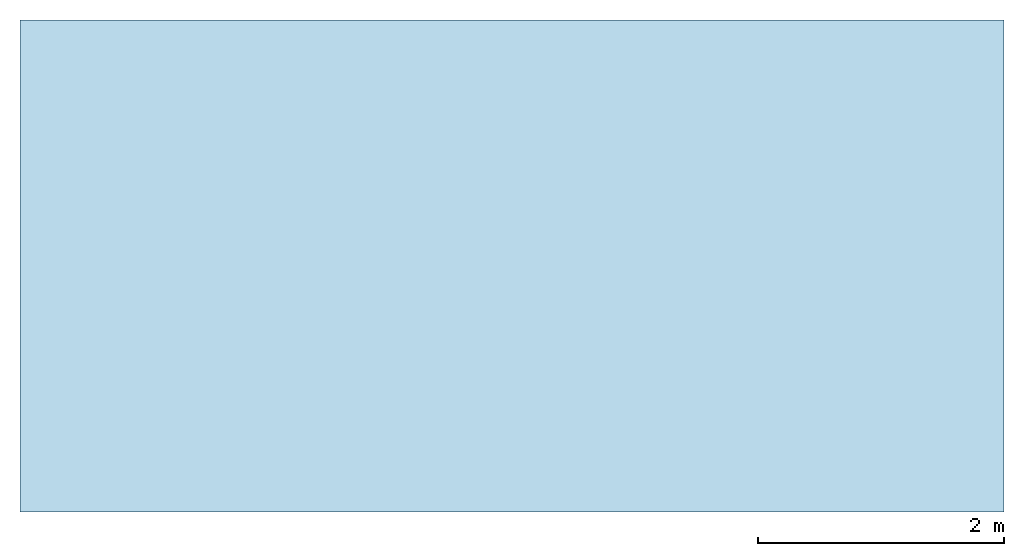
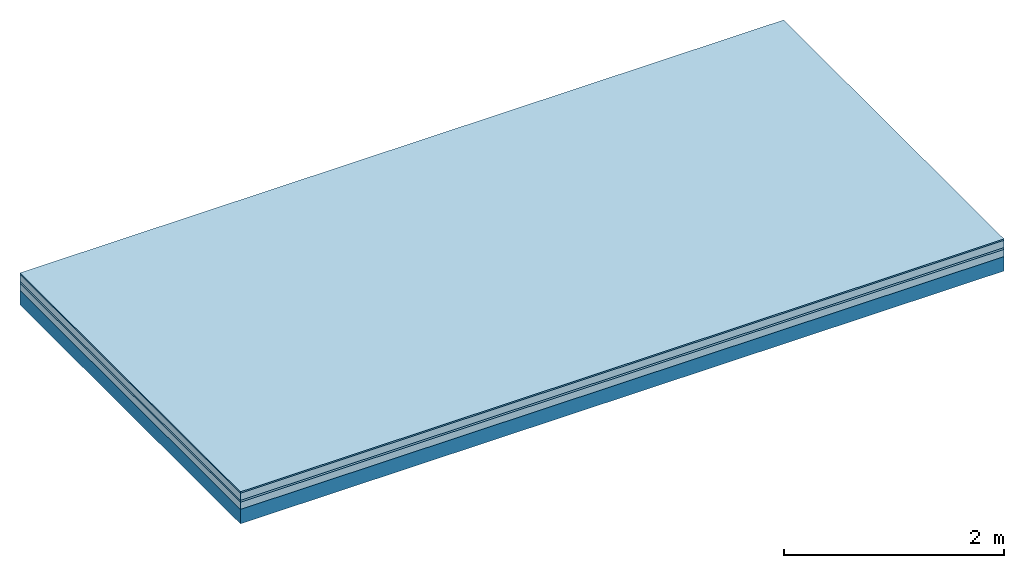
# One storey: 4 plates, 1 member, 1 element without a shape of its own.
"""IFC4 building model written with IfcOpenShell, lengths in metres."""

from ifc_helpers import new_model, si_unit, derived_unit, direction, frame, frame_2d, origin, origin_with_axes, place, context, project, spatial, rectangle, extrude, material, layer, layer_set, type_object, element, aggregate, save


model = new_model("IFC4")

# Units and contexts
plan_context = context("Plan", 3, precision=1e-05, world=origin(), true_north=direction((0.0, 1.0)))
model_context = context("Model", 3, precision=1e-05, world=origin(), true_north=direction((0.0, 1.0)))
ifc_project = project(units=[si_unit("LENGTHUNIT", "METRE"), derived_unit("SOUNDPRESSUREUNIT", [(si_unit("PRESSUREUNIT", "PASCAL", prefix="MICRO"), 0)]), si_unit("ENERGYUNIT", "JOULE", prefix="MEGA"), si_unit("MASSUNIT", "GRAM", prefix="KILO"), derived_unit("THERMALTRANSMITTANCEUNIT", [(si_unit("POWERUNIT", "WATT"), 1), (si_unit("AREAUNIT", "SQUARE_METRE"), -1), (si_unit("THERMODYNAMICTEMPERATUREUNIT", "KELVIN"), -1)]), derived_unit("AREADENSITYUNIT", [(si_unit("MASSUNIT", "GRAM", prefix="KILO"), 1), (si_unit("AREAUNIT", "SQUARE_METRE"), -1)]), derived_unit("USERDEFINED", [(si_unit("ENERGYUNIT", "JOULE", prefix="MEGA"), 1), (si_unit("AREAUNIT", "SQUARE_METRE"), -1)])], contexts=[plan_context, model_context])

# Site, building, storey
site = spatial("IfcSite", under=ifc_project)
building_placement = place(None, origin())
building = spatial("IfcBuilding", under=site, at=building_placement)
storey_placement = place(building_placement, origin())
storey = spatial("IfcBuildingStorey", under=building, at=storey_placement)

# Slab, member, plates
ifc_material_1 = material(Category="11.013")
ifc_layer_1 = layer(ifc_material_1, 0.015, Name="Flooring")
ifc_material_2 = material(Name="Cement screed", Category="04.006")
ifc_layer_2 = layer(ifc_material_2, 0.08, Name="On-material")
ifc_material_3 = material(Name="Wood fiber generic product", Category="10.009")
ifc_layer_3 = layer(ifc_material_3, 0.02, Name="Impact sound insulation")
ifc_material_4 = material(Category="10.006")
ifc_layer_4 = layer(ifc_material_4, 0.08, Name="Additional insulation")
ifc_material_5 = material(Name="no composite action")
ifc_layer_5 = layer(ifc_material_5, 0.0, Name="Bond")
ifc_layer_6 = layer(None, 0.16, Name="Supporting structure")
ifc_layer_set = layer_set([ifc_layer_1, ifc_layer_2, ifc_layer_3, ifc_layer_4, ifc_layer_5, ifc_layer_6])
slab_type = type_object("IfcSlabType", Name="A2181", PredefinedType="NOTDEFINED", material=ifc_layer_set)
slab_placement = place(None, frame((0.0, 0.0, 0.0), z_axis=(0.0, 0.0, -1.0), x_axis=(1.0, 0.0, 0.0)))
slab = element("IfcSlab", 1, at=slab_placement, inside=storey, type_object=slab_type, material=ifc_layer_set, Name="Slab #1")
ifc_material_6 = material(Name="Solid timber panel")
member_placement = place(slab_placement, origin())
member = element("IfcMember", 2, at=member_placement, material=ifc_material_6, Name="Supporting structure", context=plan_context, shape_type="SweptSolid", body=[
    extrude(rectangle(XDim=1.0, YDim=0.16, at=frame_2d((0.5, 0.08), x_axis=(1.0, 0.0))), frame((0.0, 4.0, 0.195), z_axis=(0.0, -1.0, 0.0), x_axis=(1.0, 0.0, 0.0)), (0.0, 0.0, 1.0), 4.0),
    extrude(rectangle(XDim=1.0, YDim=0.16, at=frame_2d((0.5, 0.08), x_axis=(1.0, 0.0))), frame((1.0, 4.0, 0.195), z_axis=(0.0, -1.0, 0.0), x_axis=(1.0, 0.0, 0.0)), (0.0, 0.0, 1.0), 4.0),
    extrude(rectangle(XDim=1.0, YDim=0.16, at=frame_2d((0.5, 0.08), x_axis=(1.0, 0.0))), frame((2.0, 4.0, 0.195), z_axis=(0.0, -1.0, 0.0), x_axis=(1.0, 0.0, 0.0)), (0.0, 0.0, 1.0), 4.0),
    extrude(rectangle(XDim=1.0, YDim=0.16, at=frame_2d((0.5, 0.08), x_axis=(1.0, 0.0))), frame((3.0, 4.0, 0.195), z_axis=(0.0, -1.0, 0.0), x_axis=(1.0, 0.0, 0.0)), (0.0, 0.0, 1.0), 4.0),
    extrude(rectangle(XDim=1.0, YDim=0.16, at=frame_2d((0.5, 0.08), x_axis=(1.0, 0.0))), frame((4.0, 4.0, 0.195), z_axis=(0.0, -1.0, 0.0), x_axis=(1.0, 0.0, 0.0)), (0.0, 0.0, 1.0), 4.0),
    extrude(rectangle(XDim=1.0, YDim=0.16, at=frame_2d((0.5, 0.08), x_axis=(1.0, 0.0))), frame((5.0, 4.0, 0.195), z_axis=(0.0, -1.0, 0.0), x_axis=(1.0, 0.0, 0.0)), (0.0, 0.0, 1.0), 4.0),
    extrude(rectangle(XDim=1.0, YDim=0.16, at=frame_2d((0.5, 0.08), x_axis=(1.0, 0.0))), frame((6.0, 4.0, 0.195), z_axis=(0.0, -1.0, 0.0), x_axis=(1.0, 0.0, 0.0)), (0.0, 0.0, 1.0), 4.0),
    extrude(rectangle(XDim=1.0, YDim=0.16, at=frame_2d((0.5, 0.08), x_axis=(1.0, 0.0))), frame((7.0, 4.0, 0.195), z_axis=(0.0, -1.0, 0.0), x_axis=(1.0, 0.0, 0.0)), (0.0, 0.0, 1.0), 4.0),
])
plate_1_placement = place(slab_placement, origin())
plate_1 = element("IfcPlate", 3, at=plate_1_placement, material=ifc_material_1, Name="Flooring", context=plan_context, shape_type="SweptSolid", body=[
    extrude(rectangle(XDim=8.0, YDim=4.0, at=frame_2d((4.0, 2.0), x_axis=(1.0, 0.0))), origin_with_axes(), (0.0, 0.0, 1.0), 0.015),
])
plate_2_placement = place(slab_placement, origin())
plate_2 = element("IfcPlate", 4, at=plate_2_placement, material=ifc_material_2, Name="On-material", context=plan_context, shape_type="SweptSolid", body=[
    extrude(rectangle(XDim=8.0, YDim=4.0, at=frame_2d((4.0, 2.0), x_axis=(1.0, 0.0))), frame((0.0, 0.0, 0.015), z_axis=(0.0, 0.0, 1.0), x_axis=(1.0, 0.0, 0.0)), (0.0, 0.0, 1.0), 0.08),
])
plate_3_placement = place(slab_placement, origin())
plate_3 = element("IfcPlate", 5, at=plate_3_placement, material=ifc_material_3, Name="Impact sound insulation", context=plan_context, shape_type="SweptSolid", body=[
    extrude(rectangle(XDim=8.0, YDim=4.0, at=frame_2d((4.0, 2.0), x_axis=(1.0, 0.0))), frame((0.0, 0.0, 0.095), z_axis=(0.0, 0.0, 1.0), x_axis=(1.0, 0.0, 0.0)), (0.0, 0.0, 1.0), 0.02),
])
plate_4_placement = place(slab_placement, origin())
plate_4 = element("IfcPlate", 6, at=plate_4_placement, material=ifc_material_4, Name="Additional insulation", context=plan_context, shape_type="SweptSolid", body=[
    extrude(rectangle(XDim=8.0, YDim=4.0, at=frame_2d((4.0, 2.0), x_axis=(1.0, 0.0))), frame((0.0, 0.0, 0.115), z_axis=(0.0, 0.0, 1.0), x_axis=(1.0, 0.0, 0.0)), (0.0, 0.0, 1.0), 0.08),
])
aggregate(slab, [plate_1, plate_2, plate_3, plate_4, member])

save(model, "model.ifc")
